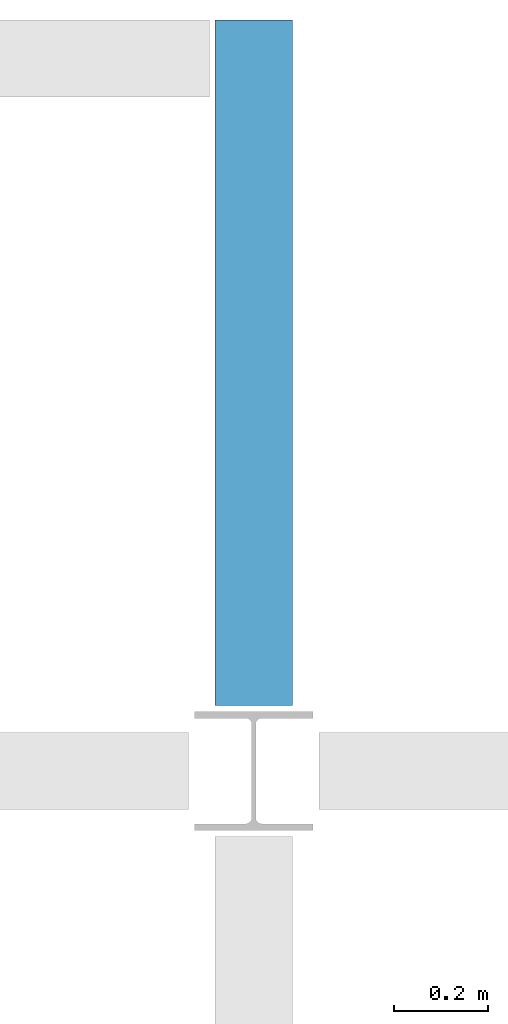
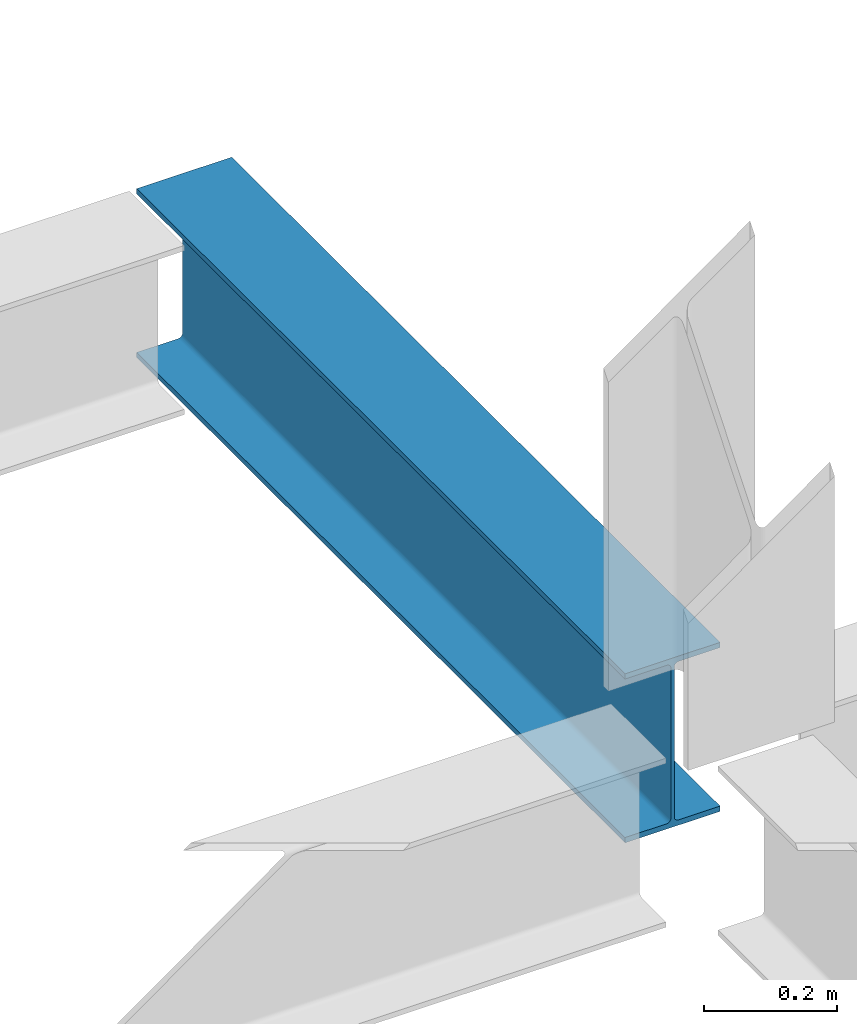
# One storey, part 3 of 3: 1 beam.
"""IFC4 building model written with IfcOpenShell, lengths in feet."""

import ifcopenshell
import ifcopenshell.guid

model = None  # the IFC model being written
_history = None  # IfcOwnerHistory: only IFC2X3 demands one
_inside = {}  # id of a spatial element -> (the spatial element, [elements in it])
_under = {}  # id of a project, library or spatial element -> (it, [spatial elements below it])
_declared = {}  # id of a project -> (the project, [libraries it declares])
_typed = {}  # id of a type object -> (the type object, [elements of that type])
_made_of = {}  # id of a material, layer set ... -> (it, [elements and type objects made of it])


def new_model(schema):
    """Start an empty IFC model of exactly this schema.

    Asked for "IFC4X3", IfcOpenShell would pick the latest addendum, in which some entities
    have other attributes; the version numbers below select the first issue.
    IFC2X3 requires an IfcOwnerHistory on every rooted entity: one is made here for all.
    """
    global model, _history
    if schema == "IFC4X3":
        model = ifcopenshell.file(schema_version=(4, 3, 0, 0))
    else:
        model = ifcopenshell.file(schema=schema)
    _inside.clear()
    _under.clear()
    _declared.clear()
    _typed.clear()
    _made_of.clear()
    _history = None
    if model.schema == "IFC2X3":
        org = make("IfcOrganization", Name="unknown")
        user = make(
            "IfcPersonAndOrganization",
            ThePerson=make("IfcPerson", FamilyName="unknown"),
            TheOrganization=org,
        )
        app = make(
            "IfcApplication",
            ApplicationDeveloper=org,
            Version="unknown",
            ApplicationFullName="unknown",
            ApplicationIdentifier="unknown",
        )
        _history = make(
            "IfcOwnerHistory",
            OwningUser=user,
            OwningApplication=app,
            ChangeAction="ADDED",
            CreationDate=0,
        )
    return model


def make(cls, **values):
    """One entity of the class cls with the attributes given. An attribute that is None is left unset."""
    return model.create_entity(
        cls, **{name: value for name, value in values.items() if value is not None}
    )


def entity(cls, *values):
    """Any entity or typed value of the class cls, its attributes in the order of the schema. None: left unset."""
    e = model.create_entity(cls)
    for i, value in enumerate(values):
        if value is not None:
            e[i] = value
    return e


def rooted(cls, **values):
    """An entity with a GlobalId (a new one), such as an element, a storey or a relation."""
    return make(cls, GlobalId=ifcopenshell.guid.new(), OwnerHistory=_history, **values)


def si_unit(unit_type, name, prefix=None):
    """IfcSIUnit, for example si_unit("LENGTHUNIT", "METRE", prefix="MILLI")."""
    return make("IfcSIUnit", UnitType=unit_type, Prefix=prefix, Name=name)


def converted_unit(unit_type, name, factor, base, dimensions=None, offset=None):
    """IfcConversionBasedUnit, such as the inch: factor (a typed value) times the base unit."""
    return make(
        "IfcConversionBasedUnit"
        if offset is None
        else "IfcConversionBasedUnitWithOffset",
        ConversionOffset=offset,
        Dimensions=None
        if dimensions is None
        else entity("IfcDimensionalExponents", *dimensions),
        UnitType=unit_type,
        Name=name,
        ConversionFactor=make(
            "IfcMeasureWithUnit", ValueComponent=factor, UnitComponent=base
        ),
    )


def derived_unit(unit_type, elements):
    """IfcDerivedUnit: a product of units, each with its exponent."""
    return make(
        "IfcDerivedUnit",
        Elements=[
            make("IfcDerivedUnitElement", Unit=unit, Exponent=power)
            for unit, power in elements
        ],
        UnitType=unit_type,
    )


def assignment(units):
    """IfcUnitAssignment: the units of a project."""
    return None if units is None else make("IfcUnitAssignment", Units=units)


def point(xyz):
    """IfcCartesianPoint."""
    return None if xyz is None else make("IfcCartesianPoint", Coordinates=xyz)


def direction(xyz):
    """IfcDirection."""
    return None if xyz is None else make("IfcDirection", DirectionRatios=xyz)


def frame(location, z_axis=None, x_axis=None):
    """IfcAxis2Placement3D, a coordinate frame: its origin and axes. An axis left out is left unset."""
    return make(
        "IfcAxis2Placement3D",
        Location=point(location),
        Axis=direction(z_axis),
        RefDirection=direction(x_axis),
    )


def origin():
    """The frame at (0, 0, 0) with its axes left unset."""
    return frame((0.0, 0.0, 0.0))


def place(relative_to, where):
    """IfcLocalPlacement: puts the frame where relative to a parent placement (None: the world)."""
    return make(
        "IfcLocalPlacement", PlacementRelTo=relative_to, RelativePlacement=where
    )


def context(
    kind, dimensions, precision=None, world=None, true_north=None, identifier=None
):
    """IfcGeometricRepresentationContext, for example the 3D "Model" context."""
    return make(
        "IfcGeometricRepresentationContext",
        ContextIdentifier=identifier,
        ContextType=kind,
        CoordinateSpaceDimension=dimensions,
        Precision=precision,
        WorldCoordinateSystem=world,
        TrueNorth=true_north,
    )


def subcontext(parent, identifier, kind, view, scale=None):
    """IfcGeometricRepresentationSubContext, for example "Body" below "Model"."""
    return make(
        "IfcGeometricRepresentationSubContext",
        ContextIdentifier=identifier,
        ContextType=kind,
        ParentContext=parent,
        TargetScale=scale,
        TargetView=view,
    )


def project(units=None, contexts=None):
    """IfcProject with its units and contexts."""
    return rooted(
        "IfcProject",
        Name="project",
        RepresentationContexts=contexts,
        UnitsInContext=assignment(units),
    )


def spatial(cls, under=None, at=None, **own):
    """A site, building, storey or space (cls), placed at a placement, below another one or the project."""
    s = rooted(cls, ObjectPlacement=at, **own)
    if under is not None:
        _under.setdefault(under.id(), (under, []))[1].append(s)
    return s


def point_list(points):
    """IfcCartesianPointList2D or 3D."""
    cls = (
        "IfcCartesianPointList2D" if len(points[0]) == 2 else "IfcCartesianPointList3D"
    )
    return make(cls, CoordList=points)


def line(*indices):
    """IfcLineIndex: a straight run through numbered points of an indexed curve."""
    return model.create_entity("IfcLineIndex", indices)


def arc(*indices):
    """IfcArcIndex: an arc through three numbered points of an indexed curve."""
    return model.create_entity("IfcArcIndex", indices)


def indexed_curve(points, segments=None, self_intersect=None):
    """IfcIndexedPolyCurve: lines and arcs through numbered points (the first is 1)."""
    return make(
        "IfcIndexedPolyCurve",
        Points=point_list(points),
        Segments=segments,
        SelfIntersect=self_intersect,
    )


def outline(outer, holes=None, kind="AREA"):
    """IfcArbitraryClosedProfileDef: a profile drawn as a closed curve; with holes, ...WithVoids."""
    if holes is None:
        return make("IfcArbitraryClosedProfileDef", ProfileType=kind, OuterCurve=outer)
    return make(
        "IfcArbitraryProfileDefWithVoids",
        ProfileType=kind,
        OuterCurve=outer,
        InnerCurves=holes,
    )


def extrude(swept, where, along, depth):
    """IfcExtrudedAreaSolid: the profile swept, set in the frame where, extruded along a direction by depth."""
    return make(
        "IfcExtrudedAreaSolid",
        SweptArea=swept,
        Position=where,
        ExtrudedDirection=direction(along),
        Depth=depth,
    )


def shape(context_of_items, identifier, shape_type, items):
    """IfcShapeRepresentation: the items that make up one representation, for example the "Body"."""
    return make(
        "IfcShapeRepresentation",
        ContextOfItems=context_of_items,
        RepresentationIdentifier=identifier,
        RepresentationType=shape_type,
        Items=items,
    )


def source(mapping_origin, context_of_items, identifier, shape_type, items):
    """IfcRepresentationMap: a shape defined once, which mapped items show again and again."""
    return make(
        "IfcRepresentationMap",
        MappingOrigin=mapping_origin,
        MappedRepresentation=shape(context_of_items, identifier, shape_type, items),
    )


def transform(
    local_origin,
    x_axis=None,
    y_axis=None,
    z_axis=None,
    scale=None,
    scale2=None,
    scale3=None,
    uniform=True,
):
    """IfcCartesianTransformationOperator3D, or its non-uniform kind. x_axis, y_axis, z_axis: its Axis1, 2, 3."""
    if uniform:
        return make(
            "IfcCartesianTransformationOperator3D",
            Axis1=direction(x_axis),
            Axis2=direction(y_axis),
            LocalOrigin=point(local_origin),
            Scale=scale,
            Axis3=direction(z_axis),
        )
    return make(
        "IfcCartesianTransformationOperator3DnonUniform",
        Axis1=direction(x_axis),
        Axis2=direction(y_axis),
        LocalOrigin=point(local_origin),
        Scale=scale,
        Axis3=direction(z_axis),
        Scale2=scale2,
        Scale3=scale3,
    )


def mapped(mapping_source, mapping_target):
    """IfcMappedItem: shows the shape of a source again, moved by a transform."""
    return make(
        "IfcMappedItem", MappingSource=mapping_source, MappingTarget=mapping_target
    )


def material(Name=None, Category=None):
    """IfcMaterial."""
    return make("IfcMaterial", Name=Name, Category=Category)


def made_of(thing, what):
    """Note that an element or type object is made of a material, layer set ...; save() writes the relation."""
    if what is not None:
        _made_of.setdefault(what.id(), (what, []))[1].append(thing)
    return thing


def type_object(cls, material=None, **own):
    """A type object (cls), such as IfcWallType, which elements share."""
    return made_of(rooted(cls, **own), material)


def type_shapes(of_type, sources):
    """Give a type object the sources (RepresentationMaps) that its elements show as mapped items."""
    of_type.RepresentationMaps = sources


def element(
    cls,
    number,
    at=None,
    inside=None,
    cuts=None,
    type_object=None,
    material=None,
    context=None,
    identifier="Body",
    shape_type=None,
    held_by="IfcProductDefinitionShape",
    body=None,
    shapes=None,
    **own,
):
    """One element of the class cls, such as IfcWall. Its Tag is "e" and its number.

    at: its placement. inside: the storey or other place that contains it. cuts: it is an
    opening in that element (IfcRelVoidsElement). A single representation is given by context,
    identifier, shape_type and body (its items); several are given by shapes. held_by: the class
    of the entity that holds the representations. save() writes the other relations.
    """
    e = rooted(cls, Tag="e%d" % number, ObjectPlacement=at, **own)
    if body is not None:
        shapes = [shape(context, identifier, shape_type, body)]
    if shapes is not None:
        e.Representation = make(held_by, Representations=shapes)
    if inside is not None:
        _inside.setdefault(inside.id(), (inside, []))[1].append(e)
    if cuts is not None:
        rooted(
            "IfcRelVoidsElement", RelatingBuildingElement=cuts, RelatedOpeningElement=e
        )
    if type_object is not None:
        _typed.setdefault(type_object.id(), (type_object, []))[1].append(e)
    return made_of(e, material)


def aggregate(whole, parts):
    """IfcRelAggregates: a whole, such as a stair, and the parts it consists of."""
    return rooted("IfcRelAggregates", RelatingObject=whole, RelatedObjects=parts)


def save(model, path):
    """Write the relations noted so far, then the file.

    IfcRelAggregates (storeys below a building ...), IfcRelContainedInSpatialStructure (elements
    in a storey), IfcRelDefinesByType, IfcRelAssociatesMaterial and IfcRelDeclares: one each for
    every whole, place, type object, material and project.
    """
    for whole, parts in _under.values():
        aggregate(whole, parts)
    for where, things in _inside.values():
        rooted(
            "IfcRelContainedInSpatialStructure",
            RelatedElements=things,
            RelatingStructure=where,
        )
    for kind, things in _typed.values():
        rooted("IfcRelDefinesByType", RelatedObjects=things, RelatingType=kind)
    for what, things in _made_of.values():
        rooted("IfcRelAssociatesMaterial", RelatedObjects=things, RelatingMaterial=what)
    for by, libraries in _declared.values():
        rooted("IfcRelDeclares", RelatingContext=by, RelatedDefinitions=libraries)
    model.write(path)


model = new_model("IFC4")

# Units and contexts
model_context = context("Model", 3, precision=0.0001, world=origin(), true_north=direction((6.123233995736766e-17, 1.0)))
plan_context = context("Plan", 3, precision=0.0001, world=origin(), true_north=direction((6.123233995736766e-17, 1.0)))
body_context = subcontext(model_context, "Body", "Model", "MODEL_VIEW")
ifc_project = project(units=[converted_unit("LENGTHUNIT", "FOOT", entity("IfcLengthMeasure", 0.3048), si_unit("LENGTHUNIT", "METRE"), dimensions=[1, 0, 0, 0, 0, 0, 0]), converted_unit("AREAUNIT", "SQUARE FOOT", entity("IfcAreaMeasure", 0.09290304), si_unit("AREAUNIT", "SQUARE_METRE"), dimensions=[2, 0, 0, 0, 0, 0, 0]), converted_unit("PLANEANGLEUNIT", "DEGREE", entity("IfcPlaneAngleMeasure", 0.017453292519943278), si_unit("PLANEANGLEUNIT", "RADIAN"), dimensions=[0, 0, 0, 0, 0, 0, 0]), converted_unit("VOLUMEUNIT", "CUBIC FOOT", entity("IfcVolumeMeasure", 0.028316846592000004), si_unit("VOLUMEUNIT", "CUBIC_METRE"), dimensions=[3, 0, 0, 0, 0, 0, 0]), si_unit("PRESSUREUNIT", "PASCAL"), derived_unit("MASSDENSITYUNIT", [(si_unit("MASSUNIT", "GRAM", prefix="KILO"), 1), (si_unit("LENGTHUNIT", "METRE"), -3)]), derived_unit("VAPORPERMEABILITYUNIT", [(si_unit("LENGTHUNIT", "METRE"), -1), (si_unit("TIMEUNIT", "SECOND"), 1)]), derived_unit("USERDEFINED", [(si_unit("MASSUNIT", "GRAM", prefix="KILO"), 1), (si_unit("LENGTHUNIT", "METRE"), 3), (si_unit("TIMEUNIT", "SECOND"), -3), (si_unit("ELECTRICCURRENTUNIT", "AMPERE"), -2)]), derived_unit("MODULUSOFELASTICITYUNIT", [(si_unit("MASSUNIT", "GRAM", prefix="KILO"), 1), (si_unit("LENGTHUNIT", "METRE"), -1), (si_unit("TIMEUNIT", "SECOND"), -2)]), derived_unit("THERMALEXPANSIONCOEFFICIENTUNIT", [(si_unit("THERMODYNAMICTEMPERATUREUNIT", "KELVIN"), -1)]), derived_unit("SPECIFICHEATCAPACITYUNIT", [(si_unit("TIMEUNIT", "SECOND"), -2), (si_unit("THERMODYNAMICTEMPERATUREUNIT", "KELVIN"), -1), (si_unit("LENGTHUNIT", "METRE"), 2)]), derived_unit("THERMALCONDUCTANCEUNIT", [(si_unit("MASSUNIT", "GRAM", prefix="KILO"), 1), (si_unit("TIMEUNIT", "SECOND"), -3), (si_unit("THERMODYNAMICTEMPERATUREUNIT", "KELVIN"), -1), (si_unit("LENGTHUNIT", "METRE"), 1)])], contexts=[model_context, plan_context])

# Site, building, storey
site_placement = place(None, origin())
site = spatial("IfcSite", under=ifc_project, at=site_placement, CompositionType="ELEMENT")
building_placement = place(site_placement, origin())
building = spatial("IfcBuilding", under=site, at=building_placement, CompositionType="ELEMENT")
storey_placement = place(building_placement, frame((0.0, 0.0, 99.875)))
storey = spatial("IfcBuildingStorey", under=building, at=storey_placement, Name="STR 11", CompositionType="ELEMENT", Elevation=99.875)

# Beam
ifc_material = material(Name="Steel ASTM A992", Category="Metal")
beam_type = type_object("IfcBeamType", Name="W12X26", PredefinedType="JOIST", material=ifc_material)
shared_shape = source(origin(), body_context, "Body", "SweptSolid", [
    extrude(outline(indexed_curve([(-0.2704166666666623, -0.50833333333334), (0.2704166666666694, -0.50833333333334), (0.2704166666666694, -0.4766666666666737), (0.03458333333333741, -0.4766666666666879), (0.01690566380367642, -0.4693443361963432), (0.009583333333338828, -0.4516666666666822), (0.009583333333338828, 0.4516666666666538), (0.01690566380367642, 0.46934433619631477), (0.03458333333333741, 0.47666666666665947), (0.2704166666666694, 0.47666666666665947), (0.2704166666666694, 0.5083333333333258), (-0.2704166666666623, 0.5083333333333258), (-0.2704166666666623, 0.47666666666665947), (-0.0345833333333303, 0.47666666666665947), (-0.016905663803669313, 0.46934433619631477), (-0.009583333333331723, 0.4516666666666538), (-0.009583333333331723, -0.4516666666666822), (-0.016905663803669313, -0.4693443361963432), (-0.0345833333333303, -0.4766666666666737), (-0.2704166666666623, -0.4766666666666737)], segments=[line(1, 2, 3, 4), arc(4, 5, 6), line(6, 7), arc(7, 8, 9), line(9, 10, 11, 12, 13, 14), arc(14, 15, 16), line(16, 17), arc(17, 18, 19), line(19, 20, 1)], self_intersect=False)), frame((39.0, 44.270416666666286, 99.36666666666663), z_axis=(0.0, -1.0, 0.0), x_axis=(-1.0, 0.0, 0.0)), (0.0, 0.0, 1.0), 4.812083333333393),
])
type_shapes(beam_type, [shared_shape])
beam_placement = place(storey_placement, frame((0.0, 0.0, -99.875)))
element("IfcBeam", 1, at=beam_placement, inside=storey, type_object=beam_type, material=ifc_material, Name="W12X26", ObjectType="W Shapes:W12X26", PredefinedType="JOIST", context=body_context, shape_type="MappedRepresentation", body=[
    mapped(shared_shape, transform((0.0, 0.0, 0.0), scale=1.0)),
])

save(model, "model.ifc")
